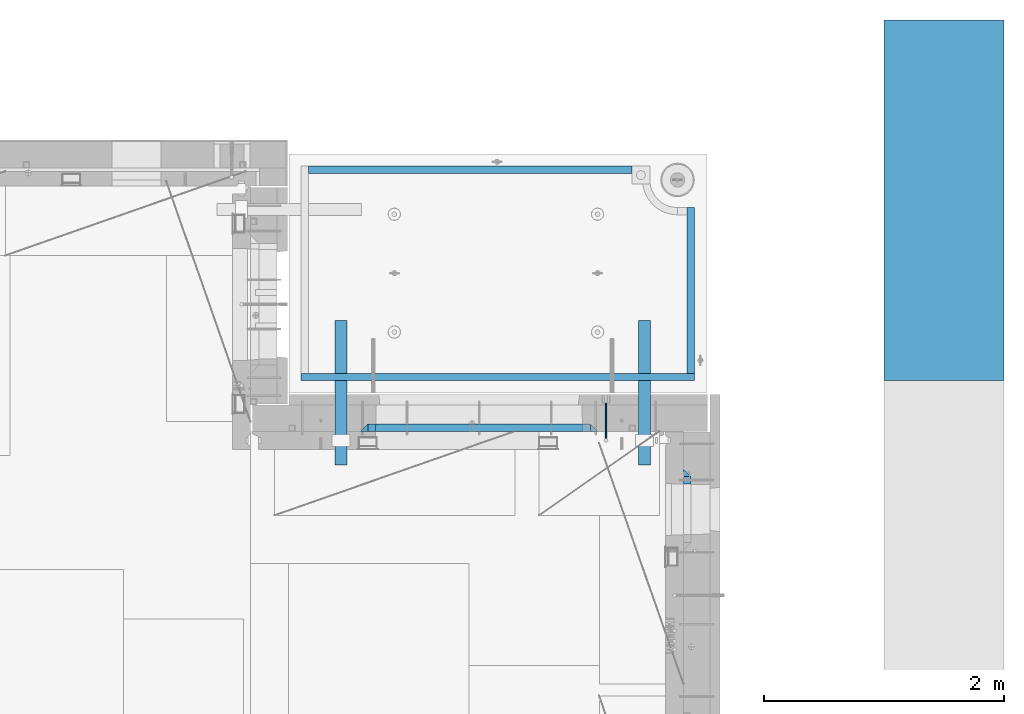
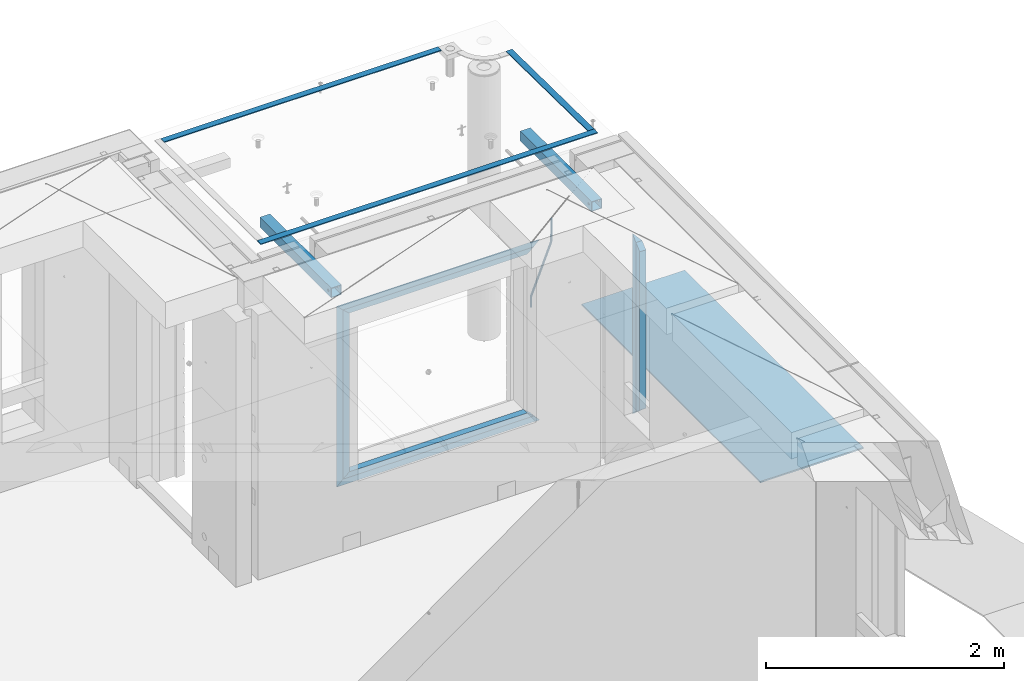
# One storey, part 117 of 325: 15 beams, 6 elements without a shape of their own.
"""IFC2X3 building model written with IfcOpenShell, lengths in millimetres."""

from ifc_helpers import new_model, si_unit, frame, origin_with_axes, place, context, subcontext, project, spatial, faceted_brep, material, type_object, element, aggregate, save


model = new_model("IFC2X3")

# Units and contexts
model_context = context("Model", 3, precision=1e-05, world=origin_with_axes())
body_context = subcontext(model_context, "Body", "Model", "MODEL_VIEW")
ifc_project = project(units=[si_unit("LENGTHUNIT", "METRE", prefix="MILLI"), si_unit("AREAUNIT", "SQUARE_METRE"), si_unit("VOLUMEUNIT", "CUBIC_METRE"), si_unit("MASSUNIT", "GRAM", prefix="KILO"), si_unit("TIMEUNIT", "SECOND"), si_unit("PLANEANGLEUNIT", "RADIAN"), si_unit("SOLIDANGLEUNIT", "STERADIAN"), si_unit("THERMODYNAMICTEMPERATUREUNIT", "DEGREE_CELSIUS"), si_unit("LUMINOUSINTENSITYUNIT", "LUMEN")], contexts=[model_context])

# Site, building, storey
site_placement = place(None, origin_with_axes())
site = spatial("IfcSite", under=ifc_project, at=site_placement, CompositionType="ELEMENT")
building_placement = place(site_placement, origin_with_axes())
building = spatial("IfcBuilding", under=site, at=building_placement, CompositionType="ELEMENT")
storey_placement = place(building_placement, origin_with_axes())
storey = spatial("IfcBuildingStorey", under=building, at=storey_placement, Name="1", CompositionType="ELEMENT", Elevation=0.0)

# Assembly, beam
assembly_1_placement = place(storey_placement, origin_with_axes())
assembly_1 = element("IfcElementAssembly", 1, at=assembly_1_placement, inside=storey, AssemblyPlace="NOTDEFINED", PredefinedType="REINFORCEMENT_UNIT")
ifc_material_1 = material()
beam_type_1 = type_object("IfcBeamType", Name="D20", PredefinedType="NOTDEFINED")
beam_1_placement = place(assembly_1_placement, frame((34415.0000001015, 20504.9951872346, 84407.5), z_axis=(0.000415599999849905, 0.999999913638203, 4.76000000899737e-07), x_axis=(0.0, 0.0, -1.0)))
beam_1 = element("IfcBeam", 2, at=beam_1_placement, type_object=beam_type_1, material=ifc_material_1, Name="JM20", ObjectType="D20", context=body_context, shape_type="Brep", body=[
    faceted_brep([(-0.00060564729210455, -9.99999998165731, 0.0), (-0.000428079845733009, -7.07106779890455, -7.07106781186667), (119.575515501536, -7.07830994756296, -7.07106481604933), (119.575337932896, -10.0072421307195, -3.43332612828817e-06), (0.0, 0.0, -10.0), (119.575943836026, -0.00724214867295814, -9.99999700418266), (0.00042843479604926, 7.07106779888636, -7.07106781186303), (119.57637202373, 7.06382565022977, -7.07106481604933), (0.00060564729210455, 9.99999998166459, 3.63797880709171e-12), (119.576549238118, 9.99275783300072, 2.99581552098971e-06), (0.000428079845733009, 7.07106779890819, 7.07106781186667), (119.576371669405, 7.06382565024978, 7.07107080768037), (0.0, 0.0, 10.0), (119.57594333493, -0.00724214864203532, 10.0000029958155), (-0.000428434810601175, -7.07106779888272, 7.07106781186667), (119.575515147211, -7.07830994754295, 7.07107080768037), (123.00654325854, -7.07836650239551, -6.96786008391246), (122.581588830741, -10.007295666459, 0.0904344953341933), (123.182419066041, -0.00729994480025198, -9.89151006310021), (123.006190977103, 7.06376911688858, -6.96788735351402), (122.581091016109, 9.99270432680532, 0.0903895128230943), (122.156136974867, 7.06377516229986, 7.14867767459873), (121.980261167351, -0.00729139528993983, 10.0723276537792), (122.156489256289, -7.07836045697513, 7.14870494419847), (237.077376207715, -7.07551629289992, -0.0988779924864502), (236.652422053201, -10.0044409119728, 6.95941204931296), (237.253252288647, -0.0044516184279928, -3.02253250974718), (237.077024472936, 7.06661932641327, -0.0989143382521434), (236.651924624995, 9.99555908263574, 6.95936064834314), (236.226970470365, 7.06663446442326, 14.0176506898479), (236.051094389448, -0.0044302100486675, 16.9413052071086), (236.227322205144, -7.07550115488812, 14.0176870356117), (256.715938387759, -7.07353516174771, 4.66794781703175), (253.858321224223, -10.0027051854922, 11.1357628166734), (257.898622435067, -0.00236892073007766, 1.98867362452802), (256.713573090979, 7.0686002544353, 4.66742272414376), (253.85497618909, 9.99729452004976, 11.1350202234971), (250.997359025234, 7.06812449537756, 17.6028352234607), (249.814674977912, -0.00304174564189452, 20.2821094159572), (250.999724322028, -7.07401092080545, 17.6033603163596), (1009.84102825288, -6.93521658215468, 337.477148757798), (1006.98341108896, -9.86438660663771, 343.944963757851), (1011.02371230032, 0.135949658781101, 334.7978745651), (1009.83866295629, 7.20691883402651, 337.476623664521), (1006.98006605446, 10.1356130998429, 343.944221163818), (1004.12244889054, 7.2064430753635, 350.412036163872), (1002.9397648431, 0.135276834424076, 353.091310356571), (1004.12481418712, -6.93569234081951, 350.412561257146), (1010.86335274603, -6.9350288225487, 337.928918327354), (1009.37086865908, -9.86394812736762, 344.999991477531), (1011.48104818776, 0.136033652863262, 334.999973251377), (1010.86211737194, 7.20710680115553, 337.928892551665), (1009.36912157628, 10.1360518725905, 344.9999550252), (1007.87663748935, 7.2071325677698, 352.071028175378), (1007.2589420476, 0.13607009235966, 354.999973251352), (1007.87787286344, -6.93500305593261, 352.071053951067), (1011.98104820926, -6.93502881915083, 337.92891832735), (1011.98104821818, -9.86394811943501, 344.999991477524), (1011.98104818776, 0.136033654382118, 334.999973251375), (1011.98104816627, 7.20710680455704, 337.928892551661), (1011.98104815738, 10.1360518805304, 344.999955025194), (1011.98104816629, 7.20713258024625, 352.071028175369), (1011.98104818778, 0.136070106711486, 354.999973251342), (1011.98104820927, -6.9350030434598, 352.071053951058), (1117.50000002154, -6.93502849844299, 337.928918327156), (1117.50000003044, -9.86394779872717, 344.999991477331), (1117.50000000004, 0.136033975091777, 334.999973251181), (1117.49999997855, 7.20710712526488, 337.928892551467), (1117.49999996964, 10.1360522012383, 344.999955025), (1117.49999997857, 7.20713290095409, 352.071028175174), (1117.50000000006, 0.136070427419327, 354.999973251148), (1117.50000002155, -6.93500272275196, 352.071053950864)], [[[0, 1, 2, 3]], [[1, 4, 5, 2]], [[4, 6, 7, 5]], [[6, 8, 9, 7]], [[8, 10, 11, 9]], [[10, 12, 13, 11]], [[12, 14, 15, 13]], [[14, 0, 3, 15]], [[14, 12, 10, 8, 6, 4, 1, 0]], [[3, 2, 16, 17]], [[2, 5, 18, 16]], [[5, 7, 19, 18]], [[7, 9, 20, 19]], [[9, 11, 21, 20]], [[11, 13, 22, 21]], [[13, 15, 23, 22]], [[15, 3, 17, 23]], [[17, 16, 24, 25]], [[16, 18, 26, 24]], [[18, 19, 27, 26]], [[19, 20, 28, 27]], [[20, 21, 29, 28]], [[21, 22, 30, 29]], [[22, 23, 31, 30]], [[23, 17, 25, 31]], [[25, 24, 32, 33]], [[24, 26, 34, 32]], [[26, 27, 35, 34]], [[27, 28, 36, 35]], [[28, 29, 37, 36]], [[29, 30, 38, 37]], [[30, 31, 39, 38]], [[31, 25, 33, 39]], [[33, 32, 40, 41]], [[32, 34, 42, 40]], [[34, 35, 43, 42]], [[35, 36, 44, 43]], [[36, 37, 45, 44]], [[37, 38, 46, 45]], [[38, 39, 47, 46]], [[39, 33, 41, 47]], [[41, 40, 48, 49]], [[40, 42, 50, 48]], [[42, 43, 51, 50]], [[43, 44, 52, 51]], [[44, 45, 53, 52]], [[45, 46, 54, 53]], [[46, 47, 55, 54]], [[47, 41, 49, 55]], [[49, 48, 56, 57]], [[48, 50, 58, 56]], [[50, 51, 59, 58]], [[51, 52, 60, 59]], [[52, 53, 61, 60]], [[53, 54, 62, 61]], [[54, 55, 63, 62]], [[55, 49, 57, 63]], [[57, 56, 64, 65]], [[56, 58, 66, 64]], [[58, 59, 67, 66]], [[59, 60, 68, 67]], [[60, 61, 69, 68]], [[61, 62, 70, 69]], [[62, 63, 71, 70]], [[63, 57, 65, 71]], [[66, 67, 68, 69, 70, 71, 65, 64]]]),
])

# Assemblies, beams
assembly_2_placement = place(storey_placement, origin_with_axes())
assembly_2 = element("IfcElementAssembly", 3, at=assembly_2_placement, inside=storey, AssemblyPlace="NOTDEFINED", PredefinedType="REINFORCEMENT_UNIT")
assembly_3_placement = place(assembly_2_placement, origin_with_axes())
assembly_3 = element("IfcElementAssembly", 4, at=assembly_3_placement, AssemblyPlace="NOTDEFINED", PredefinedType="NOTDEFINED")
ifc_material_2 = material(Name="Undefined/350")
beam_type_2 = type_object("IfcBeamType", Name="100X100X5", PredefinedType="NOTDEFINED")
beam_2_placement = place(assembly_3_placement, frame((34735.0001432011, 21500.0034426031, 84555.0), z_axis=(0.0, 0.0, 1.0), x_axis=(-2.2242999997242e-05, -0.999999999752625, 0.0)))
beam_2 = element("IfcBeam", 5, at=beam_2_placement, type_object=beam_type_2, material=ifc_material_2, ObjectType="100X100X5", context=body_context, shape_type="Brep", body=[
    faceted_brep([(1143.75108023171, 44.9999999999982, -10.8253175473074), (1143.75107855316, 50.0255964196231, -10.8253175473074), (1139.17576100585, 50.0255948914664, -6.25), (1139.1757626844, 44.9999999999982, -6.25), (1150.00108023171, 44.9999999999982, -12.5), (1150.00107855316, 50.0255985071226, -12.5), (1156.2510802317, 44.9999999999982, -10.8253175473074), (1156.25107855315, 50.0256005946221, -10.8253175473074), (1160.82639777901, 44.9999999999982, -6.25), (1160.82639610046, 50.0256021227788, -6.25), (1162.50108023171, 44.9999999999982, 0.0), (1162.50107855316, 50.0256026821226, 0.0), (1160.82639777901, 44.9999999999982, 6.25), (1160.82639610046, 50.0256021227788, 6.25), (1156.2510802317, 44.9999999999982, 10.8253175473074), (1156.25107855315, 50.0256005946221, 10.8253175473074), (1150.00108023171, 44.9999999999982, 12.5), (1150.00107855316, 50.0255985071226, 12.5), (1143.75108023171, 44.9999999999982, 10.8253175473074), (1143.75107855316, 50.0255964196231, 10.8253175473074), (1139.1757626844, 44.9999999999982, 6.25), (1139.17576100585, 50.0255948914664, 6.25), (1137.5010802317, 44.9999999999982, 0.0), (1137.50107855316, 50.0255943321226, 0.0), (1143.75111195316, -49.9744035792783, -10.8253175473074), (1143.75111029171, -44.9999999999991, -10.8253175473074), (1139.1757927444, -44.9999999999991, -6.25), (1139.17579440585, -49.9744051074349, -6.25), (1150.00111195316, -49.9744014917787, -12.5), (1150.00111029171, -44.9999999999991, -12.5), (1156.25111195316, -49.9743994042774, -10.8253175473074), (1156.25111029171, -44.9999999999991, -10.8253175473074), (1160.82642950046, -49.9743978761207, -6.25), (1160.82642783901, -44.9999999999991, -6.25), (1162.50111195316, -49.9743973167779, 0.0), (1162.50111029171, -44.9999999999991, 0.0), (1160.82642950046, -49.9743978761207, 6.25), (1160.82642783901, -44.9999999999991, 6.25), (1156.25111195316, -49.9743994042774, 10.8253175473074), (1156.25111029171, -44.9999999999991, 10.8253175473074), (1150.00111195316, -49.9744014917787, 12.5), (1150.00111029171, -44.9999999999991, 12.5), (1143.75111195316, -49.9744035792783, 10.8253175473074), (1143.75111029171, -44.9999999999991, 10.8253175473074), (1139.17579440585, -49.9744051074349, 6.25), (1139.1757927444, -44.9999999999991, 6.25), (1137.50111195316, -49.9744056667778, 0.0), (1137.50111029171, -44.9999999999991, 0.0), (1.81898940354586e-12, -50.0000000000009, -50.0), (1.81898940354586e-12, 49.9999999999991, -50.0), (1200.00449189278, 49.9999999999982, -50.0), (1200.00449189278, -50.0000000000009, -50.0), (1.81898940354586e-12, 49.9999999999991, 50.0), (1.81898940354586e-12, -50.0000000000009, 50.0), (1200.00449189278, -50.0000000000009, 50.0), (1200.00449189278, 49.9999999999982, 50.0), (0.0, 44.9999999999991, 45.0), (1.81898940354586e-12, -45.0000000000009, 45.0), (1.81898940354586e-12, -45.0000000000009, -45.0), (0.0, 44.9999999999991, -45.0), (1200.00449189278, 44.9999999999982, -45.0), (1200.00449189278, 44.9999999999982, 45.0), (1200.00449189278, -45.0000000000009, 45.0), (1200.00449189278, -45.0000000000009, -45.0)], [[[0, 1, 2, 3]], [[4, 5, 1, 0]], [[6, 7, 5, 4]], [[8, 9, 7, 6]], [[10, 11, 9, 8]], [[12, 13, 11, 10]], [[14, 15, 13, 12]], [[16, 17, 15, 14]], [[18, 19, 17, 16]], [[20, 21, 19, 18]], [[22, 23, 21, 20]], [[3, 2, 23, 22]], [[24, 25, 26, 27]], [[28, 29, 25, 24]], [[30, 31, 29, 28]], [[32, 33, 31, 30]], [[34, 35, 33, 32]], [[36, 37, 35, 34]], [[38, 39, 37, 36]], [[40, 41, 39, 38]], [[42, 43, 41, 40]], [[44, 45, 43, 42]], [[46, 47, 45, 44]], [[27, 26, 47, 46]], [[48, 49, 50, 51]], [[52, 53, 54, 55]], [[49, 52, 55, 50], [15, 17, 19, 21, 23, 2, 1, 5, 7, 9, 11, 13]], [[48, 53, 52, 49], [56, 57, 58, 59]], [[56, 59, 60, 61], [6, 4, 0, 3, 22, 20, 18, 16, 14, 12, 10, 8]], [[57, 56, 61, 62]], [[58, 57, 62, 63], [39, 41, 43, 45, 47, 26, 25, 29, 31, 33, 35, 37]], [[59, 58, 63, 60]], [[54, 51, 50, 55], [62, 61, 60, 63]], [[53, 48, 51, 54], [30, 28, 24, 27, 46, 44, 42, 40, 38, 36, 34, 32]]]),
])
aggregate(assembly_3, [beam_2])
assembly_4_placement = place(assembly_2_placement, origin_with_axes())
assembly_4 = element("IfcElementAssembly", 6, at=assembly_4_placement, AssemblyPlace="NOTDEFINED", PredefinedType="NOTDEFINED")
beam_3_placement = place(assembly_4_placement, frame((32210.0001432011, 21500.0034426031, 84555.0), z_axis=(0.0, 0.0, 1.0), x_axis=(-2.2242999997242e-05, -0.999999999752625, 0.0)))
beam_3 = element("IfcBeam", 7, at=beam_3_placement, type_object=beam_type_2, material=ifc_material_2, ObjectType="100X100X5", context=body_context, shape_type="Brep", body=[
    faceted_brep([(1143.75108023171, 44.9999999999982, -10.8253175473074), (1143.75107855316, 50.0255964196231, -10.8253175473074), (1139.17576100585, 50.0255948914664, -6.25), (1139.1757626844, 44.9999999999982, -6.25), (1150.00108023171, 44.9999999999982, -12.5), (1150.00107855316, 50.0255985071226, -12.5), (1156.2510802317, 44.9999999999982, -10.8253175473074), (1156.25107855315, 50.0256005946221, -10.8253175473074), (1160.82639777901, 44.9999999999982, -6.25), (1160.82639610046, 50.0256021227788, -6.25), (1162.50108023171, 44.9999999999982, 0.0), (1162.50107855316, 50.0256026821226, 0.0), (1160.82639777901, 44.9999999999982, 6.25), (1160.82639610046, 50.0256021227788, 6.25), (1156.2510802317, 44.9999999999982, 10.8253175473074), (1156.25107855315, 50.0256005946221, 10.8253175473074), (1150.00108023171, 44.9999999999982, 12.5), (1150.00107855316, 50.0255985071226, 12.5), (1143.75108023171, 44.9999999999982, 10.8253175473074), (1143.75107855316, 50.0255964196231, 10.8253175473074), (1139.1757626844, 44.9999999999982, 6.25), (1139.17576100585, 50.0255948914664, 6.25), (1137.5010802317, 44.9999999999982, 0.0), (1137.50107855316, 50.0255943321226, 0.0), (1143.75111195316, -49.9744035792783, -10.8253175473074), (1143.75111029171, -44.9999999999991, -10.8253175473074), (1139.1757927444, -44.9999999999991, -6.25), (1139.17579440585, -49.9744051074349, -6.25), (1150.00111195316, -49.9744014917787, -12.5), (1150.00111029171, -44.9999999999991, -12.5), (1156.25111195316, -49.9743994042774, -10.8253175473074), (1156.25111029171, -44.9999999999991, -10.8253175473074), (1160.82642950046, -49.9743978761207, -6.25), (1160.82642783901, -44.9999999999991, -6.25), (1162.50111195316, -49.9743973167779, 0.0), (1162.50111029171, -44.9999999999991, 0.0), (1160.82642950046, -49.9743978761207, 6.25), (1160.82642783901, -44.9999999999991, 6.25), (1156.25111195316, -49.9743994042774, 10.8253175473074), (1156.25111029171, -44.9999999999991, 10.8253175473074), (1150.00111195316, -49.9744014917787, 12.5), (1150.00111029171, -44.9999999999991, 12.5), (1143.75111195316, -49.9744035792783, 10.8253175473074), (1143.75111029171, -44.9999999999991, 10.8253175473074), (1139.17579440585, -49.9744051074349, 6.25), (1139.1757927444, -44.9999999999991, 6.25), (1137.50111195316, -49.9744056667778, 0.0), (1137.50111029171, -44.9999999999991, 0.0), (1.81898940354586e-12, -50.0000000000009, -50.0), (1.81898940354586e-12, 49.9999999999991, -50.0), (1200.00449189278, 49.9999999999982, -50.0), (1200.00449189278, -50.0000000000009, -50.0), (1.81898940354586e-12, 49.9999999999991, 50.0), (1.81898940354586e-12, -50.0000000000009, 50.0), (1200.00449189278, -50.0000000000009, 50.0), (1200.00449189278, 49.9999999999982, 50.0), (0.0, 44.9999999999991, 45.0), (1.81898940354586e-12, -45.0000000000009, 45.0), (1.81898940354586e-12, -45.0000000000009, -45.0), (0.0, 44.9999999999991, -45.0), (1200.00449189278, 44.9999999999982, -45.0), (1200.00449189278, 44.9999999999982, 45.0), (1200.00449189278, -45.0000000000009, 45.0), (1200.00449189278, -45.0000000000009, -45.0)], [[[0, 1, 2, 3]], [[4, 5, 1, 0]], [[6, 7, 5, 4]], [[8, 9, 7, 6]], [[10, 11, 9, 8]], [[12, 13, 11, 10]], [[14, 15, 13, 12]], [[16, 17, 15, 14]], [[18, 19, 17, 16]], [[20, 21, 19, 18]], [[22, 23, 21, 20]], [[3, 2, 23, 22]], [[24, 25, 26, 27]], [[28, 29, 25, 24]], [[30, 31, 29, 28]], [[32, 33, 31, 30]], [[34, 35, 33, 32]], [[36, 37, 35, 34]], [[38, 39, 37, 36]], [[40, 41, 39, 38]], [[42, 43, 41, 40]], [[44, 45, 43, 42]], [[46, 47, 45, 44]], [[27, 26, 47, 46]], [[48, 49, 50, 51]], [[52, 53, 54, 55]], [[49, 52, 55, 50], [15, 17, 19, 21, 23, 2, 1, 5, 7, 9, 11, 13]], [[48, 53, 52, 49], [56, 57, 58, 59]], [[56, 59, 60, 61], [6, 4, 0, 3, 22, 20, 18, 16, 14, 12, 10, 8]], [[57, 56, 61, 62]], [[58, 57, 62, 63], [39, 41, 43, 45, 47, 26, 25, 29, 31, 33, 35, 37]], [[59, 58, 63, 60]], [[54, 51, 50, 55], [62, 61, 60, 63]], [[53, 48, 51, 54], [30, 28, 24, 27, 46, 44, 42, 40, 38, 36, 34, 32]]]),
])
aggregate(assembly_4, [beam_3])
ifc_material_3 = material(Name="CONCRETE/Concrete_Undefined")
beam_type_3 = type_object("IfcBeamType", PredefinedType="NOTDEFINED")
beam_4_placement = place(assembly_2_placement, frame((31939.9962088653, 22755.0460044164, 84704.8214945677), z_axis=(-6.06120000110142e-05, 1.00000033869885e-09, 0.999999998163093), x_axis=(0.999999998046552, -1.52670000006885e-05, 6.06120000021532e-05)))
beam_4 = element("IfcBeam", 8, at=beam_4_placement, type_object=beam_type_3, material=ifc_material_3, context=body_context, shape_type="Brep", body=[
    faceted_brep([(2.5465851649642e-11, 29.9999999999982, -4.99999999998545), (-2.91038304567337e-11, 29.9999999999982, 5.0), (2689.99575395095, 29.9999999999964, 5.0), (2689.99575395095, 30.0000000000036, -4.99999999998545), (-2.5465851649642e-11, -30.0000000000018, 5.0), (2689.99575395095, -30.0000000000036, 5.00000000001455), (2.72848410531878e-11, -30.0000000000018, -4.99999999998545), (2689.99575395095, -29.9999999999964, -4.99999999998545)], [[[0, 1, 2, 3]], [[1, 4, 5, 2]], [[4, 6, 7, 5]], [[6, 0, 3, 7]], [[5, 7, 3, 2]], [[6, 4, 1, 0]]]),
])
beam_5_placement = place(assembly_2_placement, frame((35120.0586113047, 21059.9283388168, 84725.6638339053), z_axis=(-5.46000002942176e-07, 0.0130421150000144, 0.999914948001093), x_axis=(-4.18520000064741e-05, 0.999914947125351, -0.0130421150016393)))
beam_5 = element("IfcBeam", 9, at=beam_5_placement, type_object=beam_type_3, material=ifc_material_3, context=body_context, shape_type="Brep", body=[
    faceted_brep([(2.5465851649642e-11, 29.9999999999982, -4.99999999998545), (-2.91038304567337e-11, 29.9999999999982, 5.0), (1380.14316164461, 30.0, 5.00000000001455), (1380.1431616447, 29.9999999999927, -5.0), (-2.5465851649642e-11, -30.0000000000018, 5.0), (1380.14316164461, -30.0, 5.00000000001455), (2.72848410531878e-11, -30.0000000000018, -4.99999999998545), (1380.1431616447, -30.0, -5.0)], [[[0, 1, 2, 3]], [[1, 4, 5, 2]], [[4, 6, 7, 5]], [[6, 0, 3, 7]], [[5, 7, 3, 2]], [[6, 4, 1, 0]]]),
])
beam_6_placement = place(assembly_2_placement, frame((31879.9986204165, 21030.068155681, 84725.2788443041), z_axis=(-0.000117617000009658, 3.00000101585662e-09, 0.999999993083121), x_axis=(0.999999992839137, -2.20899999960382e-05, 0.000117616999982089)))
beam_6 = element("IfcBeam", 10, at=beam_6_placement, type_object=beam_type_3, material=ifc_material_3, context=body_context, shape_type="Brep", body=[
    faceted_brep([(2.5465851649642e-11, 29.9999999999982, -4.99999999998545), (-2.91038304567337e-11, 29.9999999999982, 5.0), (3270.06002088557, 30.0, 5.0), (3270.06002088557, 30.0000000000036, -5.0), (-2.5465851649642e-11, -30.0000000000018, 5.0), (3270.06002088557, -30.0, 5.0), (2.72848410531878e-11, -30.0000000000018, -4.99999999998545), (3270.06002088558, -29.9999999999964, -5.0)], [[[0, 1, 2, 3]], [[1, 4, 5, 2]], [[4, 6, 7, 5]], [[6, 0, 3, 7]], [[5, 7, 3, 2]], [[6, 4, 1, 0]]]),
])
aggregate(assembly_2, [assembly_3, assembly_4, beam_4, beam_5, beam_6])

# Assembly, beam
assembly_5_placement = place(storey_placement, origin_with_axes())
assembly_5 = element("IfcElementAssembly", 11, at=assembly_5_placement, inside=storey, AssemblyPlace="NOTDEFINED", PredefinedType="REINFORCEMENT_UNIT")
ifc_material_4 = material(Name="CONCRETE/C25/30")
beam_type_4 = type_object("IfcBeamType", PredefinedType="NOTDEFINED")
beam_7_placement = place(assembly_5_placement, frame((35090.0, 20234.9999664753, 84175.0), z_axis=(0.0, -1.0, 0.0), x_axis=(0.0, 0.0, -1.0)))
beam_7 = element("IfcBeam", 12, at=beam_7_placement, type_object=beam_type_4, material=ifc_material_4, Name="SK", context=body_context, shape_type="Brep", body=[
    faceted_brep([(60.0000000000073, 30.0, 30.0), (0.0, -30.0, -30.0), (60.0000000000073, -30.0, 30.0), (1795.00000000001, 30.0, 30.0), (1855.0, -30.0, -30.0), (1795.00000000001, -30.0, 30.0)], [[[0, 1, 2]], [[3, 4, 1, 0]], [[4, 5, 2, 1]], [[5, 3, 0, 2]], [[5, 4, 3]]]),
])

# Beam
beam_8_placement = place(assembly_1_placement, frame((34345.0010086818, 20609.9951872276, 84145.0), z_axis=(0.0, 0.0, -1.0), x_axis=(-1.0, 3.00000001838171e-08, 0.0)))
beam_8 = element("IfcBeam", 13, at=beam_8_placement, type_object=beam_type_4, material=ifc_material_4, Name="SK", context=body_context, shape_type="Brep", body=[
    faceted_brep([(60.0000000000073, 30.0, 30.0), (0.0, -30.0, -30.0), (60.0000000000073, -30.0, 30.0), (1910.00076293945, 30.0, 30.0), (1970.00076293945, -30.0, -30.0), (1910.00076293945, -30.0, 30.0)], [[[0, 1, 2]], [[1, 0, 3, 4]], [[2, 1, 4, 5]], [[0, 2, 5, 3]], [[4, 3, 5]]]),
])

beam_9_placement = place(assembly_1_placement, frame((34285.0010086818, 20609.9951872276, 84085.0), z_axis=(0.0, 0.0, -1.0), x_axis=(-1.0, 3.00000001838171e-08, 0.0)))
beam_9 = element("IfcBeam", 14, at=beam_9_placement, type_object=beam_type_4, material=ifc_material_4, Name="SK", context=body_context, shape_type="Brep", body=[
    faceted_brep([(64.0548169935064, -30.0, 24.9041288395529), (65.6764386151262, 30.0, 26.294090229203), (0.0, 30.0, -30.0), (0.0, -30.0, -30.0), (64.0548169935064, -30.0, 24.0540540540533), (65.6764386151262, 30.0, 25.6756756756804), (1785.9467088854, -30.0, 24.0540540540533), (1784.32508726378, 30.0, 25.6756756756804), (1784.32508726378, 30.0, 26.2934362810774), (1850.00076293945, 30.0, -30.0), (1850.00076293945, -30.0, -30.0), (1785.9467088854, -30.0, 24.9034748914128)], [[[0, 1, 2, 3]], [[4, 5, 1, 0]], [[6, 7, 5, 4]], [[2, 1, 5, 7, 8, 9]], [[3, 2, 9, 10]], [[6, 4, 0, 3, 10, 11]], [[7, 6, 11, 8]], [[10, 9, 8, 11]]]),
])

beam_10_placement = place(assembly_1_placement, frame((32405.0002457424, 20609.9951872276, 84175.0), z_axis=(1.0, 0.0, 0.0), x_axis=(0.0, 0.0, -1.0)))
beam_10 = element("IfcBeam", 15, at=beam_10_placement, type_object=beam_type_4, material=ifc_material_4, Name="SK", context=body_context, shape_type="Brep", body=[
    faceted_brep([(60.0000000000073, 30.0, 30.0), (0.0, -30.0, -30.0), (60.0000000000073, -30.0, 30.0), (1795.00000000001, 30.0, 30.0), (1855.0, -30.0, -30.0), (1795.00000000001, -30.0, 30.0)], [[[0, 1, 2]], [[3, 4, 1, 0]], [[4, 5, 2, 1]], [[5, 3, 0, 2]], [[5, 4, 3]]]),
])

beam_11_placement = place(assembly_1_placement, frame((32375.0002457424, 20609.9951872276, 82350.0), z_axis=(0.0, 0.0, 1.0), x_axis=(1.0, 0.0, 0.0)))
beam_11 = element("IfcBeam", 16, at=beam_11_placement, type_object=beam_type_4, material=ifc_material_4, Name="SK", context=body_context, shape_type="Brep", body=[
    faceted_brep([(1970.00076293945, -30.0, -30.0), (1910.00076293945, 30.0, 30.0), (1910.00076293945, -30.0, 30.0), (60.0000000000073, 30.0, 30.0), (60.0000000000073, -30.0, 30.0), (0.0, -30.0, -30.0)], [[[0, 1, 2]], [[3, 4, 2, 1]], [[4, 5, 0, 2]], [[5, 3, 1, 0]], [[3, 5, 4]]]),
])

beam_12_placement = place(assembly_1_placement, frame((32435.0002457424, 20609.9951872276, 82410.0), z_axis=(0.0, 0.0, 1.0), x_axis=(1.0, 0.0, 0.0)))
beam_12 = element("IfcBeam", 17, at=beam_12_placement, type_object=beam_type_4, material=ifc_material_4, Name="SK", context=body_context, shape_type="Brep", body=[
    faceted_brep([(1785.94594594595, -30.0, 24.9041288395238), (1850.00076293945, -30.0, -30.0), (1850.00076293945, 30.0, -30.0), (1784.32432432433, 30.0, 26.2940902291739), (1784.32432432433, 30.0, 25.6756756756804), (1785.94594594595, -30.0, 24.0540540540533), (65.6756756756768, 30.0, 25.6756756756804), (64.0540540540533, -30.0, 24.0540540540533), (65.6756756756768, 30.0, 26.293436281092), (64.0540540540533, -30.0, 24.9034748914419), (0.0, -30.0, -30.0), (0.0, 30.0, -30.0)], [[[0, 1, 2, 3]], [[4, 5, 0, 3]], [[5, 4, 6, 7]], [[7, 6, 8, 9]], [[1, 0, 5, 7, 9, 10]], [[10, 11, 2, 1]], [[6, 4, 3, 2, 11, 8]], [[10, 9, 8, 11]]]),
])

beam_type_5 = type_object("IfcBeamType", PredefinedType="NOTDEFINED")
beam_13_placement = place(assembly_5_placement, frame((35090.0, 20169.9999664753, 84115.0), z_axis=(0.0, -1.0, 0.0), x_axis=(0.0, 0.0, -1.0)))
beam_13 = element("IfcBeam", 18, at=beam_13_placement, type_object=beam_type_5, material=ifc_material_4, Name="SK", context=body_context, shape_type="Brep", body=[
    faceted_brep([(0.0, -30.0, -35.0), (54.9034748914273, -30.0, 29.0540540540533), (56.2934362811066, 30.0, 30.6756756756768), (0.0, 30.0, -35.0), (1735.0, 30.0, -35.0), (1735.0, -30.0, -35.0), (1680.09652510857, -30.0, 29.0540540540533), (1678.70656371891, 30.0, 30.6756756756768)], [[[0, 1, 2, 3]], [[4, 5, 0, 3]], [[1, 0, 5, 6]], [[2, 1, 6, 7]], [[3, 2, 7, 4]], [[5, 4, 7, 6]]]),
])

aggregate(assembly_5, [beam_7, beam_13])

beam_14_placement = place(assembly_1_placement, frame((32470.0002457424, 20609.9951872276, 84115.0), z_axis=(1.0, 0.0, 0.0), x_axis=(0.0, 0.0, -1.0)))
beam_14 = element("IfcBeam", 19, at=beam_14_placement, type_object=beam_type_5, material=ifc_material_4, Name="SK", context=body_context, shape_type="Brep", body=[
    faceted_brep([(0.0, -30.0, -35.0), (54.9034748914273, -30.0, 29.0540540540533), (56.2934362811066, 30.0, 30.6756756756768), (0.0, 30.0, -35.0), (1678.70656371891, 30.0, 30.6756756756768), (1735.0, 30.0, -35.0), (1735.0, -30.0, -35.0), (1680.09652510857, -30.0, 29.0540540540533)], [[[0, 1, 2, 3]], [[3, 2, 4, 5]], [[5, 6, 0, 3]], [[1, 0, 6, 7]], [[2, 1, 7, 4]], [[6, 5, 4, 7]]]),
])

aggregate(assembly_1, [beam_1, beam_8, beam_9, beam_10, beam_14, beam_11, beam_12])

# Assembly, beam
assembly_6_placement = place(storey_placement, origin_with_axes())
assembly_6 = element("IfcElementAssembly", 20, at=assembly_6_placement, inside=storey, Name="Steel Assembly", AssemblyPlace="NOTDEFINED", PredefinedType="NOTDEFINED")
ifc_material_5 = material()
beam_type_6 = type_object("IfcBeamType", PredefinedType="NOTDEFINED")
beam_15_placement = place(assembly_6_placement, frame((37224.9964796872, 24000.0002194537, 80592.5), z_axis=(1.0, 0.0, 0.0), x_axis=(0.0, -1.0, 0.0)))
beam_15 = element("IfcBeam", 21, at=beam_15_placement, type_object=beam_type_6, material=ifc_material_5, context=body_context, shape_type="Brep", body=[
    faceted_brep([(0.0, 7.5, -500.0), (0.0, 7.5, 500.0), (3000.0, 7.5, 500.0), (3000.0, 7.5, -500.0), (0.0, -7.5, 500.0), (3000.0, -7.5, 500.0), (0.0, -7.5, -500.0), (3000.0, -7.5, -500.0)], [[[0, 1, 2, 3]], [[1, 4, 5, 2]], [[4, 6, 7, 5]], [[6, 0, 3, 7]], [[5, 7, 3, 2]], [[6, 4, 1, 0]]]),
])
aggregate(assembly_6, [beam_15])

save(model, "model.ifc")
